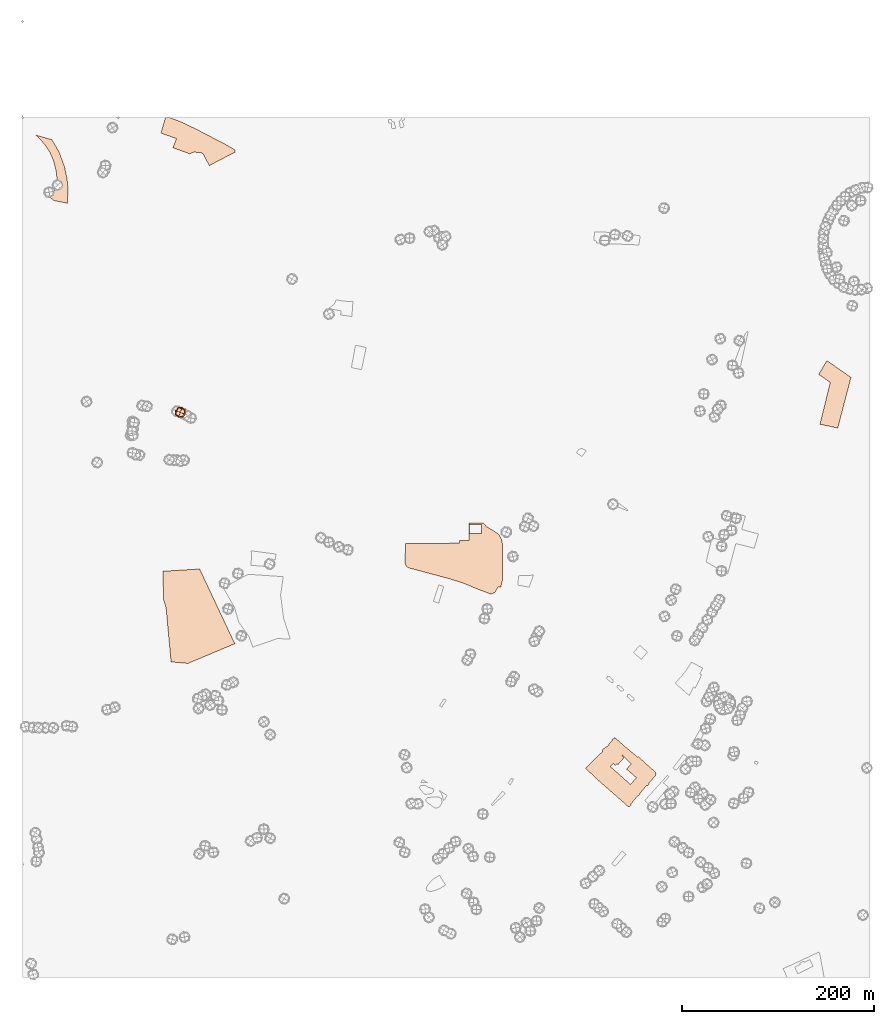
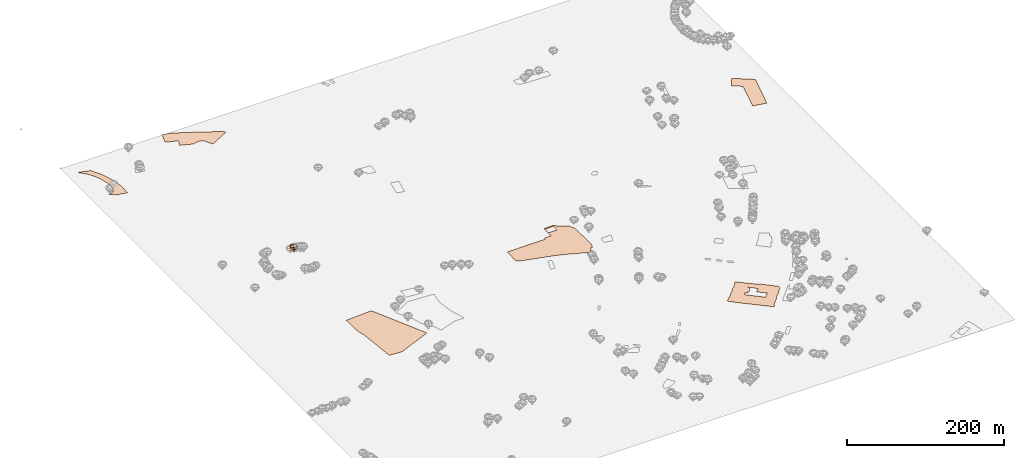
# Not in any storey, part 70 of 92: 2 geographic elements.
"""IFC4 model written with IfcOpenShell, lengths in metres."""

from ifc_helpers import new_model, si_unit, origin_with_axes, place, context, subcontext, project, spatial, triangles, material, element, save


model = new_model("IFC4")

# Units and contexts
model_context = context("Model", 3, precision=1e-05, world=origin_with_axes())
body_context = subcontext(model_context, "Body", "Model", "MODEL_VIEW")
ifc_project = project(units=[si_unit("VOLUMEUNIT", "CUBIC_METRE"), si_unit("LENGTHUNIT", "METRE"), si_unit("AREAUNIT", "SQUARE_METRE")], contexts=[model_context])

# Site
site_placement = place(None, origin_with_axes())
site = spatial("IfcSite", under=ifc_project, at=site_placement)

# Geographic elements
ifc_material_1 = material(Name="construction")
geographic_element_1_placement = place(site_placement, origin_with_axes())
element("IfcGeographicElement", 1, at=geographic_element_1_placement, inside=site, material=ifc_material_1, Name="cw_surface_construction", context=body_context, shape_type="Tessellation", body=[
    triangles([(36.788986409410455, -34.04020340736179, 0.0), (30.54611624901683, -23.377988584723433, 0.0), (22.717879767014683, -27.814788250017894, 0.0), (26.85268318803192, -34.04020340736179, 0.0), (33.7053008597483, -28.581364880145482, 0.0), (14.006912061685112, -18.616020636282677, 0.0), (842.7213241632438, -276.73341366836735, 0.0), (850.596018683831, -324.2604239907731, 0.0), (839.2137042631246, -253.87584975630995, 0.0), (834.2426561475767, -270.6241246140116, 0.0), (832.0591093406055, -320.311452724096, 0.0), (864.3941890979082, -271.39068225066467, 0.0), (830.7350362474574, -268.30120369128525, 0.0), (43.55450000714851, -51.014981907722, 0.0), (35.58687041591677, -58.68062712559807, 0.0), (35.86561864742699, -68.97117526537183, 0.0), (33.7053008597483, -76.0328636074581, 0.0), (32.26508267013767, -44.998610117628445, 0.0), (32.752892075280556, -86.83445254585158, 0.0), (26.271938712244477, -22.141047986209266, 0.0), (29.96539076670387, -79.5404740108401, 0.0), (28.409027480630655, -36.38056620556796, 0.0), (27.61924082468503, -80.4928732985706, 0.0), (47.61959737681371, -74.38358899258344, 0.0), (33.7053008597483, -28.575544757428876, 0.0), (22.717879767014683, -27.80898016515767, 0.0), (24.924655593278413, -80.67871020127937, 0.0), (46.73689464369801, -89.7381084476281, 0.0), (46.0864821035075, -62.350845412396325, 0.0), (38.32791368590842, -36.75223407552472, 0.0), (30.54611624901683, -23.372197286088216, 0.0), (17.351919330019484, -22.141047986209266, 0.0), (221.72267343262115, -35.03327062213426, 0.0), (157.00605587943042, -31.757949224585285, 0.0), (185.2063512091905, -36.54317052770774, 0.0), (188.31903979438798, -38.0298414139887, 0.0), (199.92203939511055, -22.141047986209266, 0.0), (178.19111140895203, -36.45025385699159, 0.0), (221.4671732138779, -36.47348287628411, 0.0), (220.1895581593149, -33.174932459442616, 0.0), (160.49042776678266, -22.187506618340382, 0.0), (174.61380445095523, -38.21567594251316, 0.0), (194.79999315742404, -50.43425167704042, 0.0), (221.8155895097912, -35.68368909778555, 0.0), (221.21163500818574, -33.98795525723369, 0.0), (212.87236010174817, -28.87752479047885, 0.0), (160.3568656542193, -22.141047986209266, 0.0), (616.375698197871, -674.2958820739118, 0.0), (616.3292395657398, -674.2552360385185, 0.0), (616.3292395657398, -674.3423401124968, 0.0), (650.545895408218, -697.9664616612073, 0.0), (641.6723293162095, -667.6058675372431, 0.0), (640.6037849320164, -689.255503452615, 0.0), (639.9301374370726, -689.9756220441576, 0.0), (635.2610618239588, -674.8069204983472, 0.0), (644.8779624687887, -703.1930479824474, 0.0), (653.4495489358103, -694.7840670246578, 0.0), (616.3292395657398, -648.4591726957458, 0.0), (637.6536733658392, -692.2520849282988, 0.0), (649.941936158244, -698.6168931948723, 0.0), (651.3124601674241, -697.1766750052617, 0.0), (660.2324842980178, -684.3309133756521, 0.0), (630.5687577850986, -658.3141648528633, 0.0), (633.6350162283767, -673.1576601285784, 0.0), (635.1681457467887, -695.0860442754606, 0.0), (645.7374456793492, -703.5414832718352, 0.0), (652.3345465130321, -697.3160491210168, 0.0), (660.1860262594327, -686.0266507774804, 0.0), (651.6376688117036, -675.4573520320122, 0.0), (617.2119500149546, -648.2559235253049, 0.0), (624.9240547552808, -664.4466829265116, 0.0), (630.1274022637182, -680.0799648581723, 0.0), (635.307521049636, -694.8537540825354, 0.0), (643.391293363146, -701.9618909664695, 0.0), (645.5748401701172, -703.7970024840529, 0.0), (648.0603689762598, -700.8468980404285, 0.0), (653.4960069743953, -695.9687470085763, 0.0), (660.6506113936516, -686.7932084141336, 0.0), (661.0919675085781, -685.0974710123053, 0.0), (660.8596749414686, -683.7501878933392, 0.0), (642.2762909403679, -667.0716000935151, 0.0), (640.4411806098766, -666.3979395405576, 0.0), (617.9320564388025, -647.2802857215446, 0.0), (616.6312191907269, -648.2094654867199, 0.0), (616.3292395657398, -656.984298749998, 0.0), (634.7267896318623, -716.4104739207373, 0.0), (644.4133797087541, -705.0978465579084, 0.0), (634.1692884204732, -696.0616820792209, 0.0), (616.3292395657398, -680.1496519160498, 0.0), (642.2530595468911, -707.6298286542674, 0.0), (632.5664718441835, -718.9656850363888, 0.0), (643.0196243060971, -707.6530576735599, 0.0), (626.8288515501036, -714.7379655382015, 0.0), (634.9590821989717, -717.40934074379, 0.0), (635.7488759774703, -715.2257939368188, 0.0), (644.4830667666316, -705.9573202717316, 0.0), (618.8147671847903, -682.3564277423136, 0.0), (616.3292395657398, -705.556614940567, 0.0), (632.1483453420957, -719.4302844157137, 0.0), (633.5885581897916, -718.9889140556813, 0.0), (620.1852917875166, -674.3423401124968, 0.0), (621.2770655619685, -675.4108939934272, 0.0), (626.2713500419416, -669.5338951319966, 0.0), (625.9461408041159, -670.1843076721871, 0.0), (627.3166654068422, -668.186593019556, 0.0), (618.6289332498119, -676.3865128037129, 0.0), (479.05029879991616, -434.31470426170733, 0.0), (484.36978220485184, -427.4156238030373, 0.0), (480.74603620174446, -423.18790311775786, 0.0), (479.07352781920866, -425.0927005061267, 0.0), (500.63024765741056, -444.9072344006525, 0.0), (465.73993779098174, -423.16467409846535, 0.0), (465.8793309002113, -441.56222475813377, 0.0), (466.1116210931365, -425.0927005061267, 0.0), (466.088392073844, -434.26824622312233, 0.0), (462.4181690386771, -441.56222475813377, 0.0), (496.8903375643661, -435.12772705949845, 0.0), (466.088392073844, -431.2252162055907, 0.0), (461.67482142784206, -445.00015047782256, 0.0), (499.6313998278323, -440.12201131689176, 0.0), (490.03771989264976, -430.57479891703156, 0.0), (478.818008606991, -423.09498585349564, 0.0), (466.1116210931365, -430.11021378281254, 0.0), (600.3997972055522, -666.2121073862174, 0.0), (613.2687878544543, -677.4318376653507, 0.0), (616.3815144266008, -674.2958820739118, 0.0), (603.6983559320388, -663.2387739233006, 0.0), (616.6370146453439, -648.2094654867199, 0.0), (624.9298695001454, -664.4466829265116, 0.0), (628.228428226632, -656.2641991519299, 0.0), (617.2177591211314, -648.2559235253049, 0.0), (615.2897315263779, -650.4859283708611, 0.0), (628.228428226632, -667.7452416529982, 0.0), (617.937877712674, -647.2802857215446, 0.0), (615.2432734877929, -649.3709164513458, 0.0), (612.2467110055835, -653.4360328144854, 0.0), (596.334661848938, -670.3236817879422, 0.0), (626.8346490821319, -714.7379655382015, 0.0), (628.228428226632, -715.9691225541794, 0.0), (598.4485215980317, -689.8827059669875, 0.0), (618.8205804457897, -682.3564277423136, 0.0), (587.34497440231, -679.0810980351196, 0.0), (599.6100105496066, -690.9280118351508, 0.0), (628.228428226632, -690.7537846937197, 0.0), (620.1911115775227, -674.3423401124968, 0.0), (626.2771526191115, -669.5338951319966, 0.0), (610.5741836295732, -656.084160007307, 0.0), (605.18501316676, -661.9147008301526, 0.0), (621.2828564907966, -675.4108939934272, 0.0), (608.4835718932466, -657.0597978110673, 0.0), (625.9519463490162, -670.1843076721871, 0.0), (627.3224774807493, -668.186593019556, 0.0), (605.3940933338671, -659.6614669653038, 0.0), (618.6347482914496, -676.3865128037129, 0.0), (455.7978415598859, -444.3729622085559, 0.0), (400.0012243954457, -467.46281868772286, 0.0), (445.9021843739007, -481.6558776814043, 0.0), (399.18819922347035, -461.98071790263367, 0.0), (402.13831316383187, -469.92511372620424, 0.0), (459.90941596161065, -486.13911639180935, 0.0), (399.07205412700773, -464.95406086228775, 0.0), (400.9768527024687, -468.8797983613037, 0.0), (413.82262382881555, -473.0842888401985, 0.0), (461.6515924085495, -482.0043129707921, 0.0), (455.7978415598859, -441.6086827967188, 0.0), (399.443718435688, -444.8375449685906, 0.0), (496.26315404346815, -489.9254845234388, 0.0), (498.95773927487477, -490.0880876584864, 0.0), (488.76010483808676, -497.5911273671306, 0.0), (475.5426788997969, -492.57361171626036, 0.0), (493.0110533555666, -495.68632879166955, 0.0), (500.97868294679836, -481.93462591291456, 0.0), (149.7352968669742, -511.76096208988815, 0.0), (172.61608979832414, -569.8340326417324, 0.0), (184.74177082334012, -471.2724110902762, 0.0), (147.04071163556762, -503.2358265388987, 0.0), (154.9386541689218, -568.2544403363667, 0.0), (221.4671732138779, -549.2993991491386, 0.0), (146.48321517254718, -473.6882480901726, 0.0), (221.21163500818574, -33.99374536877675, 0.0), (165.46149487580504, -4.864289267315927, 0.0), (160.49042776678266, -22.193327594279477, 0.0), (163.21407301414803, -34.04020340736179, 0.0), (212.87236010174817, -28.883323137473738, 0.0), (157.00605587943042, -31.763759516694986, 0.0), (221.23488302095274, -34.04020340736179, 0.0), (220.1895581593149, -33.18074868701309, 0.0), (181.07154778817326, -12.344109453404782, 0.0), (151.572102360067, 0.0, 0.0), (144.41581346203856, -16.52537091300706, 0.0), (149.77564754121593, 0.0, 0.0), (149.19128460836183, 0.0, 0.0), (152.64712331003054, -8.881784197001252e-16, 0.0)], [[1, 2, 3], [3, 4, 1], [1, 5, 2], [2, 6, 3], [7, 8, 9], [9, 10, 7], [7, 11, 8], [8, 12, 9], [9, 13, 10], [14, 15, 16], [16, 17, 14], [14, 18, 15], [17, 19, 14], [14, 20, 18], [17, 21, 19], [20, 22, 18], [21, 23, 19], [19, 24, 14], [14, 25, 20], [20, 26, 22], [23, 27, 19], [19, 28, 24], [24, 29, 14], [14, 30, 25], [25, 31, 20], [20, 32, 26], [33, 34, 35], [35, 36, 33], [33, 37, 34], [34, 38, 35], [36, 39, 33], [33, 40, 37], [37, 41, 34], [34, 42, 38], [36, 43, 39], [39, 44, 33], [33, 45, 40], [40, 46, 37], [37, 47, 41], [48, 49, 50], [51, 52, 53], [53, 54, 51], [52, 55, 53], [54, 56, 51], [51, 57, 52], [52, 58, 55], [54, 59, 56], [56, 60, 51], [51, 61, 57], [57, 62, 52], [52, 63, 58], [58, 64, 55], [59, 65, 56], [56, 66, 60], [61, 67, 57], [57, 68, 62], [62, 69, 52], [63, 70, 58], [58, 71, 64], [55, 72, 53], [59, 73, 65], [65, 74, 56], [56, 75, 66], [66, 76, 60], [67, 77, 57], [57, 78, 68], [68, 79, 62], [62, 80, 69], [69, 81, 52], [52, 82, 63], [63, 83, 70], [70, 84, 58], [58, 85, 71], [86, 87, 88], [88, 89, 86], [86, 90, 87], [87, 75, 88], [89, 91, 86], [90, 92, 87], [75, 74, 88], [89, 93, 91], [91, 94, 86], [86, 95, 90], [92, 96, 87], [75, 56, 74], [74, 65, 88], [88, 97, 89], [89, 98, 93], [93, 99, 91], [91, 100, 94], [71, 101, 102], [102, 103, 71], [71, 49, 101], [102, 104, 103], [103, 105, 71], [71, 85, 49], [49, 106, 101], [107, 108, 109], [109, 110, 107], [107, 111, 108], [109, 112, 110], [107, 113, 111], [112, 114, 110], [107, 115, 113], [113, 116, 111], [111, 117, 108], [112, 118, 114], [115, 112, 113], [116, 119, 111], [111, 120, 117], [117, 121, 108], [109, 122, 112], [118, 123, 114], [115, 118, 112], [124, 125, 126], [126, 127, 124], [128, 129, 130], [130, 131, 128], [128, 132, 129], [129, 133, 130], [130, 134, 131], [128, 135, 132], [132, 136, 129], [137, 138, 139], [139, 125, 137], [137, 140, 138], [139, 141, 125], [125, 124, 137], [137, 142, 140], [140, 143, 138], [139, 144, 141], [145, 146, 147], [147, 148, 145], [145, 149, 146], [146, 129, 147], [147, 150, 148], [148, 126, 145], [149, 151, 146], [146, 152, 129], [129, 136, 147], [150, 153, 148], [148, 127, 126], [126, 154, 145], [155, 156, 157], [157, 119, 155], [155, 158, 156], [156, 159, 157], [157, 160, 119], [119, 116, 155], [158, 161, 156], [156, 162, 159], [159, 163, 157], [160, 164, 119], [116, 165, 155], [155, 166, 158], [167, 168, 164], [164, 169, 167], [168, 111, 164], [164, 170, 169], [169, 171, 167], [168, 172, 111], [111, 119, 164], [164, 160, 170], [173, 174, 175], [175, 176, 173], [173, 177, 174], [174, 178, 175], [175, 179, 176], [180, 181, 182], [182, 183, 180], [180, 184, 181], [182, 185, 183], [183, 186, 180], [180, 187, 184], [184, 188, 181], [182, 181, 189], [190, 182, 191], [189, 191, 182], [191, 192, 190], [181, 193, 189]], closed=False),
])
ifc_material_2 = material(Name="tree")
geographic_element_2_placement = place(site_placement, origin_with_axes())
element("IfcGeographicElement", 2, at=geographic_element_2_placement, inside=site, material=ifc_material_2, Name="cw_instances_tree_81", context=body_context, shape_type="Tessellation", body=[
    triangles([(166.15718862527504, -307.44605963593597, 5.891642322528913), (166.15718862527504, -307.44605963593597, 5.891642322528913), (166.15718862527504, -307.44605963593597, 5.891642322528913), (166.15718862527504, -307.44605963593597, 0.0), (166.15718862527504, -307.44605963593597, 0.0), (166.15718862527504, -307.44605963593597, 0.0), (165.40989597186598, -309.3012021345492, 5.891642322528913), (165.40989597186598, -309.3012021345492, 5.891642322528913), (165.40989597186598, -309.3012021345492, 5.891642322528913), (165.40989597186598, -309.3012021345492, 0.0), (165.40989597186598, -309.3012021345492, 0.0), (165.40989597186598, -309.3012021345492, 0.0), (164.30204612666182, -306.69876698252693, 5.891642322528913), (164.30204612666182, -306.69876698252693, 5.891642322528913), (164.30204612666182, -306.69876698252693, 5.891642322528913), (164.30204612666182, -306.69876698252693, 0.0), (164.30204612666182, -306.69876698252693, 0.0), (164.30204612666182, -306.69876698252693, 0.0), (163.5547534732528, -308.5539094811401, 5.891642322528913), (163.5547534732528, -308.5539094811401, 5.891642322528913), (163.5547534732528, -308.5539094811401, 5.891642322528913), (163.5547534732528, -308.5539094811401, 0.0), (163.5547534732528, -308.5539094811401, 0.0), (163.5547534732528, -308.5539094811401, 0.0), (169.17950092685095, -305.96830375315403, 8.775985518088625), (169.17950092685095, -305.96830375315403, 8.775985518088625), (169.17950092685095, -305.96830375315403, 8.775985518088625), (169.17950092685095, -305.96830375315403, 8.775985518088625), (169.17950092685095, -305.96830375315403, 8.775985518088625), (169.17950092685095, -305.96830375315403, 8.775985518088625), (169.17950132881828, -305.9683033975949, 4.651836057284381), (169.17950132881828, -305.9683033975949, 4.651836057284381), (169.17950132881828, -305.9683033975949, 4.651836057284381), (169.17950132881828, -305.9683033975949, 4.651836057284381), (169.17950132881828, -305.9683033975949, 4.651836057284381), (169.17950132881828, -305.9683033975949, 4.651836057284381), (166.56397748652574, -312.46130103893137, 8.775985518088625), (166.56397748652574, -312.46130103893137, 8.775985518088625), (166.56397748652574, -312.46130103893137, 8.775985518088625), (166.56397748652574, -312.46130103893137, 8.775985518088625), (166.56397748652574, -312.46130103893137, 8.775985518088625), (166.56397748652574, -312.46130103893137, 8.775985518088625), (166.56397748652574, -312.46130103893137, 4.651836057284381), (166.56397748652574, -312.46130103893137, 4.651836057284381), (166.56397748652574, -312.46130103893137, 4.651836057284381), (166.56397748652574, -312.46130103893137, 4.651836057284381), (166.56397748652574, -312.46130103893137, 4.651836057284381), (166.56397748652574, -312.46130103893137, 4.651836057284381), (162.68650301963055, -303.35277928627704, 8.775985518088625), (162.68650301963055, -303.35277928627704, 8.775985518088625), (162.68650301963055, -303.35277928627704, 8.775985518088625), (162.68650301963055, -303.35277928627704, 8.775985518088625), (162.68650301963055, -303.35277928627704, 8.775985518088625), (162.68650301963055, -303.35277928627704, 8.775985518088625), (162.68650346486473, -303.35277946562724, 4.651836057284381), (162.68650346486473, -303.35277946562724, 4.651836057284381), (162.68650346486473, -303.35277946562724, 4.651836057284381), (162.68650346486473, -303.35277946562724, 4.651836057284381), (162.68650346486473, -303.35277946562724, 4.651836057284381), (162.68650346486473, -303.35277946562724, 4.651836057284381), (160.07097908766286, -309.84577715023056, 8.775985518088625), (160.07097908766286, -309.84577715023056, 8.775985518088625), (160.07097908766286, -309.84577715023056, 8.775985518088625), (160.07097908766286, -309.84577715023056, 8.775985518088625), (160.07097908766286, -309.84577715023056, 8.775985518088625), (160.07097908766286, -309.84577715023056, 8.775985518088625), (160.070979177338, -309.8457769276135, 4.651836057284381), (160.070979177338, -309.8457769276135, 4.651836057284381), (160.070979177338, -309.8457769276135, 4.651836057284381), (160.070979177338, -309.8457769276135, 4.651836057284381), (160.070979177338, -309.8457769276135, 4.651836057284381), (160.070979177338, -309.8457769276135, 4.651836057284381), (160.66731716331077, -306.31270087063484, 4.199962323387604), (160.66731716331077, -306.31270087063484, 4.199962323387604), (160.66731716331077, -306.31270087063484, 4.199962323387604), (160.66731716331077, -306.31270087063484, 4.199962323387604), (166.21957948228325, -303.94911768362374, 4.199962323387604), (166.21957948228325, -303.94911768362374, 4.199962323387604), (166.21957948228325, -303.94911768362374, 4.199962323387604), (166.21957948228325, -303.94911768362374, 4.199962323387604), (170.17750205318487, -305.5434569121238, 6.713911141185063), (170.17750205318487, -305.5434569121238, 6.713911141185063), (170.17750205318487, -305.5434569121238, 6.713911141185063), (170.17750205318487, -305.5434569121238, 6.713911141185063), (159.0729779273378, -310.2706234600879, 6.713911141185063), (159.0729779273378, -310.2706234600879, 6.713911141185063), (159.0729779273378, -310.2706234600879, 6.713911141185063), (159.0729779273378, -310.2706234600879, 6.713911141185063), (166.98882383037423, -313.45930273042933, 6.713911141185063), (166.98882383037423, -313.45930273042933, 6.713911141185063), (166.98882383037423, -313.45930273042933, 6.713911141185063), (166.98882383037423, -313.45930273042933, 6.713911141185063), (162.26165685572735, -302.3547784327049, 6.713911141185063), (162.26165685572735, -302.3547784327049, 6.713911141185063), (162.26165685572735, -302.3547784327049, 6.713911141185063), (162.26165685572735, -302.3547784327049, 6.713911141185063), (163.03090082351412, -311.8649633263155, 9.22785889848684), (163.03090082351412, -311.8649633263155, 9.22785889848684), (163.03090082351412, -311.8649633263155, 9.22785889848684), (163.03090082351412, -311.8649633263155, 9.22785889848684), (168.58316327932562, -309.5013796122606, 9.227860283022869), (168.58316327932562, -309.5013796122606, 9.227860283022869), (168.58316327932562, -309.5013796122606, 9.227860283022869), (168.58316327932562, -309.5013796122606, 9.227860283022869), (163.03090095274933, -311.86496287167466, 4.199962323387604), (163.03090095274933, -311.86496287167466, 4.199962323387604), (163.03090095274933, -311.86496287167466, 4.199962323387604), (163.03090095274933, -311.86496287167466, 4.199962323387604), (160.66731717825664, -306.312700833532, 9.22785889848684), (160.66731717825664, -306.312700833532, 9.22785889848684), (160.66731717825664, -306.312700833532, 9.22785889848684), (160.66731717825664, -306.312700833532, 9.22785889848684), (166.21957951011038, -303.94911769483315, 9.227860283022869), (166.21957951011038, -303.94911769483315, 9.227860283022869), (166.21957951011038, -303.94911769483315, 9.227860283022869), (166.21957951011038, -303.94911769483315, 9.227860283022869), (168.58316282094836, -309.50137949230117, 4.199962323387604), (168.58316282094836, -309.50137949230117, 4.199962323387604), (168.58316282094836, -309.50137949230117, 4.199962323387604), (168.58316282094836, -309.50137949230117, 4.199962323387604), (164.62524022441505, -307.90704011332514, 10.176160588398249), (164.62524022441505, -307.90704011332514, 10.176160588398249), (164.62524022441505, -307.90704011332514, 10.176160588398249), (164.62524022441505, -307.90704011332514, 10.176160588398249), (164.62524022441505, -307.90704011332514, 10.176160588398249), (164.62524022441505, -307.90704011332514, 10.176160588398249), (164.62524022441505, -307.90704011332514, 10.176160588398249), (164.62524022441505, -307.90704011332514, 10.176160588398249), (162.42949178724564, -313.3579519929938, 6.713911141185063), (162.42949178724564, -313.3579519929938, 6.713911141185063), (162.42949178724564, -313.3579519929938, 6.713911141185063), (162.42949178724564, -313.3579519929938, 6.713911141185063), (162.42949178724564, -313.3579519929938, 6.713911141185063), (162.42949178724564, -313.3579519929938, 6.713911141185063), (162.42949178724564, -313.3579519929938, 6.713911141185063), (162.42949178724564, -313.3579519929938, 6.713911141185063), (159.1743285078419, -305.71129180653924, 6.713911141185063), (159.1743285078419, -305.71129180653924, 6.713911141185063), (159.1743285078419, -305.71129180653924, 6.713911141185063), (159.1743285078419, -305.71129180653924, 6.713911141185063), (159.1743285078419, -305.71129180653924, 6.713911141185063), (159.1743285078419, -305.71129180653924, 6.713911141185063), (159.1743285078419, -305.71129180653924, 6.713911141185063), (159.1743285078419, -305.71129180653924, 6.713911141185063), (164.62524035427504, -307.9070401656356, 3.2516623715107853), (164.62524035427504, -307.9070401656356, 3.2516623715107853), (164.62524035427504, -307.9070401656356, 3.2516623715107853), (164.62524035427504, -307.9070401656356, 3.2516623715107853), (164.62524035427504, -307.9070401656356, 3.2516623715107853), (164.62524035427504, -307.9070401656356, 3.2516623715107853), (164.62524035427504, -307.9070401656356, 3.2516623715107853), (164.62524035427504, -307.9070401656356, 3.2516623715107853), (170.07615153620065, -310.1027884079854, 6.713911141185063), (170.07615153620065, -310.1027884079854, 6.713911141185063), (170.07615153620065, -310.1027884079854, 6.713911141185063), (170.07615153620065, -310.1027884079854, 6.713911141185063), (170.07615153620065, -310.1027884079854, 6.713911141185063), (170.07615153620065, -310.1027884079854, 6.713911141185063), (170.07615153620065, -310.1027884079854, 6.713911141185063), (170.07615153620065, -310.1027884079854, 6.713911141185063), (166.82098865152338, -302.456128553029, 6.713911141185063), (166.82098865152338, -302.456128553029, 6.713911141185063), (166.82098865152338, -302.456128553029, 6.713911141185063), (166.82098865152338, -302.456128553029, 6.713911141185063), (166.82098865152338, -302.456128553029, 6.713911141185063), (166.82098865152338, -302.456128553029, 6.713911141185063), (166.82098865152338, -302.456128553029, 6.713911141185063), (166.82098865152338, -302.456128553029, 6.713911141185063)], [[15, 8, 2], [7, 24, 11], [19, 16, 22], [4, 23, 17], [3, 12, 6], [14, 5, 18], [26, 127, 101], [54, 123, 114], [124, 66, 98], [128, 38, 102], [45, 133, 108], [40, 135, 89], [130, 63, 88], [131, 70, 105], [68, 141, 73], [61, 140, 86], [137, 49, 93], [142, 56, 74], [59, 145, 75], [31, 149, 79], [150, 43, 107], [146, 71, 76], [35, 154, 120], [30, 157, 83], [158, 42, 91], [153, 47, 119], [58, 164, 77], [51, 162, 96], [167, 28, 81], [165, 33, 80], [15, 21, 8], [7, 20, 24], [19, 13, 16], [4, 10, 23], [3, 9, 12], [14, 1, 5], [25, 115, 126], [53, 111, 121], [122, 112, 65], [125, 99, 37], [46, 90, 136], [39, 100, 134], [132, 97, 64], [129, 87, 69], [67, 85, 138], [62, 110, 144], [143, 109, 50], [139, 94, 55], [60, 78, 147], [32, 117, 151], [152, 118, 44], [148, 106, 72], [36, 84, 160], [29, 104, 156], [155, 103, 41], [159, 92, 48], [57, 95, 161], [52, 113, 163], [166, 116, 27], [168, 82, 34]], closed=True),
])

save(model, "model.ifc")
